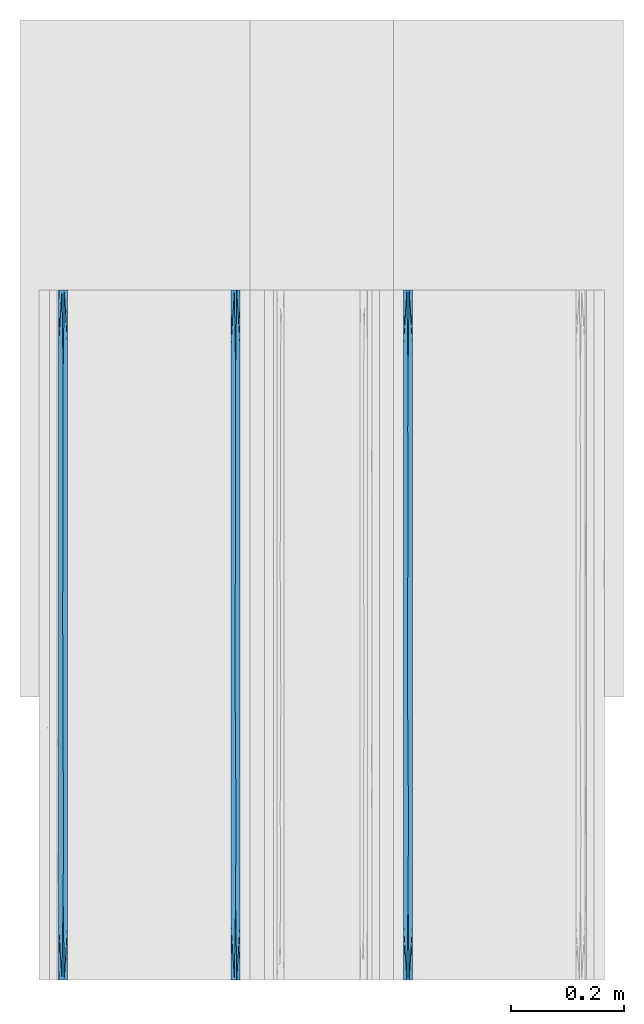
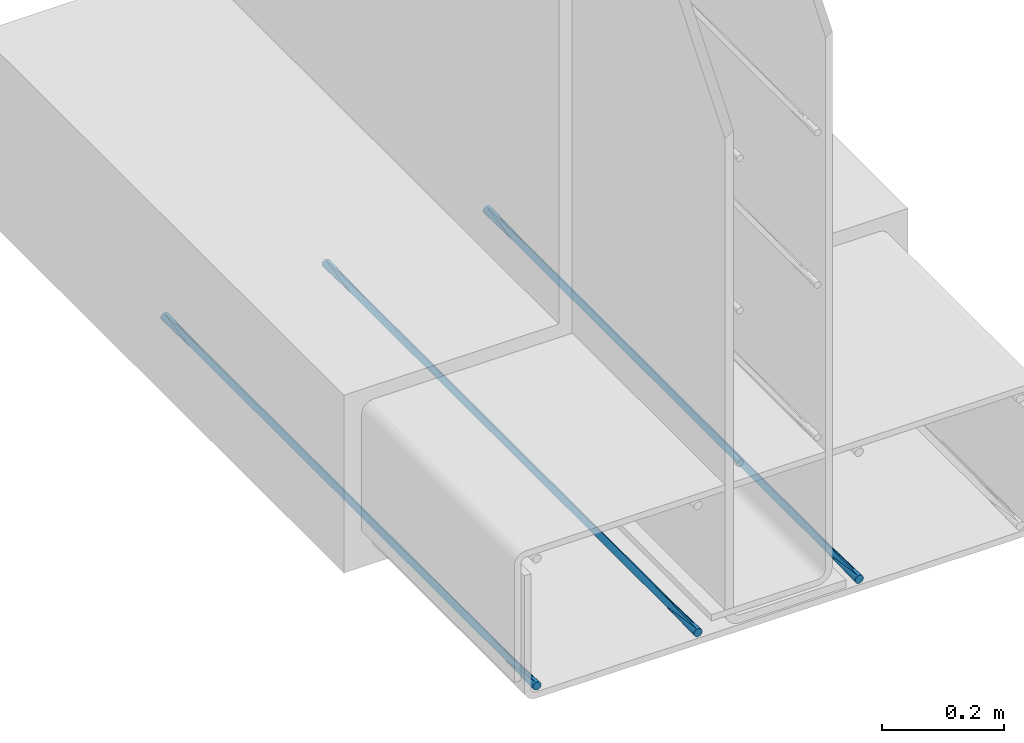
# One storey, part 5 of 10: 3 walls.
"""IFC2X3 building model written with IfcOpenShell, lengths in feet."""

import ifcopenshell
import ifcopenshell.guid

model = None  # the IFC model being written
_history = None  # IfcOwnerHistory: only IFC2X3 demands one
_inside = {}  # id of a spatial element -> (the spatial element, [elements in it])
_under = {}  # id of a project, library or spatial element -> (it, [spatial elements below it])
_declared = {}  # id of a project -> (the project, [libraries it declares])
_typed = {}  # id of a type object -> (the type object, [elements of that type])
_made_of = {}  # id of a material, layer set ... -> (it, [elements and type objects made of it])


def new_model(schema):
    """Start an empty IFC model of exactly this schema.

    Asked for "IFC4X3", IfcOpenShell would pick the latest addendum, in which some entities
    have other attributes; the version numbers below select the first issue.
    IFC2X3 requires an IfcOwnerHistory on every rooted entity: one is made here for all.
    """
    global model, _history
    if schema == "IFC4X3":
        model = ifcopenshell.file(schema_version=(4, 3, 0, 0))
    else:
        model = ifcopenshell.file(schema=schema)
    _inside.clear()
    _under.clear()
    _declared.clear()
    _typed.clear()
    _made_of.clear()
    _history = None
    if model.schema == "IFC2X3":
        org = make("IfcOrganization", Name="unknown")
        user = make(
            "IfcPersonAndOrganization",
            ThePerson=make("IfcPerson", FamilyName="unknown"),
            TheOrganization=org,
        )
        app = make(
            "IfcApplication",
            ApplicationDeveloper=org,
            Version="unknown",
            ApplicationFullName="unknown",
            ApplicationIdentifier="unknown",
        )
        _history = make(
            "IfcOwnerHistory",
            OwningUser=user,
            OwningApplication=app,
            ChangeAction="ADDED",
            CreationDate=0,
        )
    return model


def make(cls, **values):
    """One entity of the class cls with the attributes given. An attribute that is None is left unset."""
    return model.create_entity(
        cls, **{name: value for name, value in values.items() if value is not None}
    )


def entity(cls, *values):
    """Any entity or typed value of the class cls, its attributes in the order of the schema. None: left unset."""
    e = model.create_entity(cls)
    for i, value in enumerate(values):
        if value is not None:
            e[i] = value
    return e


def rooted(cls, **values):
    """An entity with a GlobalId (a new one), such as an element, a storey or a relation."""
    return make(cls, GlobalId=ifcopenshell.guid.new(), OwnerHistory=_history, **values)


def si_unit(unit_type, name, prefix=None):
    """IfcSIUnit, for example si_unit("LENGTHUNIT", "METRE", prefix="MILLI")."""
    return make("IfcSIUnit", UnitType=unit_type, Prefix=prefix, Name=name)


def converted_unit(unit_type, name, factor, base, dimensions=None, offset=None):
    """IfcConversionBasedUnit, such as the inch: factor (a typed value) times the base unit."""
    return make(
        "IfcConversionBasedUnit"
        if offset is None
        else "IfcConversionBasedUnitWithOffset",
        ConversionOffset=offset,
        Dimensions=None
        if dimensions is None
        else entity("IfcDimensionalExponents", *dimensions),
        UnitType=unit_type,
        Name=name,
        ConversionFactor=make(
            "IfcMeasureWithUnit", ValueComponent=factor, UnitComponent=base
        ),
    )


def derived_unit(unit_type, elements):
    """IfcDerivedUnit: a product of units, each with its exponent."""
    return make(
        "IfcDerivedUnit",
        Elements=[
            make("IfcDerivedUnitElement", Unit=unit, Exponent=power)
            for unit, power in elements
        ],
        UnitType=unit_type,
    )


def assignment(units):
    """IfcUnitAssignment: the units of a project."""
    return None if units is None else make("IfcUnitAssignment", Units=units)


def point(xyz):
    """IfcCartesianPoint."""
    return None if xyz is None else make("IfcCartesianPoint", Coordinates=xyz)


def direction(xyz):
    """IfcDirection."""
    return None if xyz is None else make("IfcDirection", DirectionRatios=xyz)


def frame(location, z_axis=None, x_axis=None):
    """IfcAxis2Placement3D, a coordinate frame: its origin and axes. An axis left out is left unset."""
    return make(
        "IfcAxis2Placement3D",
        Location=point(location),
        Axis=direction(z_axis),
        RefDirection=direction(x_axis),
    )


def origin():
    """The frame at (0, 0, 0) with its axes left unset."""
    return frame((0.0, 0.0, 0.0))


def place(relative_to, where):
    """IfcLocalPlacement: puts the frame where relative to a parent placement (None: the world)."""
    return make(
        "IfcLocalPlacement", PlacementRelTo=relative_to, RelativePlacement=where
    )


def context(
    kind, dimensions, precision=None, world=None, true_north=None, identifier=None
):
    """IfcGeometricRepresentationContext, for example the 3D "Model" context."""
    return make(
        "IfcGeometricRepresentationContext",
        ContextIdentifier=identifier,
        ContextType=kind,
        CoordinateSpaceDimension=dimensions,
        Precision=precision,
        WorldCoordinateSystem=world,
        TrueNorth=true_north,
    )


def subcontext(parent, identifier, kind, view, scale=None):
    """IfcGeometricRepresentationSubContext, for example "Body" below "Model"."""
    return make(
        "IfcGeometricRepresentationSubContext",
        ContextIdentifier=identifier,
        ContextType=kind,
        ParentContext=parent,
        TargetScale=scale,
        TargetView=view,
    )


def project(units=None, contexts=None):
    """IfcProject with its units and contexts."""
    return rooted(
        "IfcProject",
        Name="project",
        RepresentationContexts=contexts,
        UnitsInContext=assignment(units),
    )


def spatial(cls, under=None, at=None, **own):
    """A site, building, storey or space (cls), placed at a placement, below another one or the project."""
    s = rooted(cls, ObjectPlacement=at, **own)
    if under is not None:
        _under.setdefault(under.id(), (under, []))[1].append(s)
    return s


def faces_of(points, faces, orient=None, outer=None):
    """IfcFace entities. A face is a list of loops; a loop is a list of indices into points, from 0.

    orient and outer hold one flag for each loop. By default every Orientation is true, the
    first loop of a face is its IfcFaceOuterBound and the others are IfcFaceBound.
    """
    made = []
    for i, loops in enumerate(faces):
        bounds = []
        for j, loop in enumerate(loops):
            is_outer = j == 0 if outer is None else outer[i][j]
            bounds.append(
                make(
                    "IfcFaceOuterBound" if is_outer else "IfcFaceBound",
                    Bound=make("IfcPolyLoop", Polygon=[points[k] for k in loop]),
                    Orientation=True if orient is None else orient[i][j],
                )
            )
        made.append(make("IfcFace", Bounds=bounds))
    return made


def faceted_brep(points, faces, orient=None, outer=None, voids=None):
    """IfcFacetedBrep: a solid bounded by flat faces; with voids (closed shells), ...WithVoids."""
    shared = [point(p) for p in points]
    hull = make("IfcClosedShell", CfsFaces=faces_of(shared, faces, orient, outer))
    if voids is None:
        return make("IfcFacetedBrep", Outer=hull)
    return make(
        "IfcFacetedBrepWithVoids",
        Outer=hull,
        Voids=[
            make(cls, CfsFaces=faces_of(shared, fs, o, b)) for cls, fs, o, b in voids
        ],
    )


def shape(context_of_items, identifier, shape_type, items):
    """IfcShapeRepresentation: the items that make up one representation, for example the "Body"."""
    return make(
        "IfcShapeRepresentation",
        ContextOfItems=context_of_items,
        RepresentationIdentifier=identifier,
        RepresentationType=shape_type,
        Items=items,
    )


def material(Name=None, Category=None):
    """IfcMaterial."""
    return make("IfcMaterial", Name=Name, Category=Category)


def made_of(thing, what):
    """Note that an element or type object is made of a material, layer set ...; save() writes the relation."""
    if what is not None:
        _made_of.setdefault(what.id(), (what, []))[1].append(thing)
    return thing


def type_object(cls, material=None, **own):
    """A type object (cls), such as IfcWallType, which elements share."""
    return made_of(rooted(cls, **own), material)


def element(
    cls,
    number,
    at=None,
    inside=None,
    cuts=None,
    type_object=None,
    material=None,
    context=None,
    identifier="Body",
    shape_type=None,
    held_by="IfcProductDefinitionShape",
    body=None,
    shapes=None,
    **own,
):
    """One element of the class cls, such as IfcWall. Its Tag is "e" and its number.

    at: its placement. inside: the storey or other place that contains it. cuts: it is an
    opening in that element (IfcRelVoidsElement). A single representation is given by context,
    identifier, shape_type and body (its items); several are given by shapes. held_by: the class
    of the entity that holds the representations. save() writes the other relations.
    """
    e = rooted(cls, Tag="e%d" % number, ObjectPlacement=at, **own)
    if body is not None:
        shapes = [shape(context, identifier, shape_type, body)]
    if shapes is not None:
        e.Representation = make(held_by, Representations=shapes)
    if inside is not None:
        _inside.setdefault(inside.id(), (inside, []))[1].append(e)
    if cuts is not None:
        rooted(
            "IfcRelVoidsElement", RelatingBuildingElement=cuts, RelatedOpeningElement=e
        )
    if type_object is not None:
        _typed.setdefault(type_object.id(), (type_object, []))[1].append(e)
    return made_of(e, material)


def aggregate(whole, parts):
    """IfcRelAggregates: a whole, such as a stair, and the parts it consists of."""
    return rooted("IfcRelAggregates", RelatingObject=whole, RelatedObjects=parts)


def save(model, path):
    """Write the relations noted so far, then the file.

    IfcRelAggregates (storeys below a building ...), IfcRelContainedInSpatialStructure (elements
    in a storey), IfcRelDefinesByType, IfcRelAssociatesMaterial and IfcRelDeclares: one each for
    every whole, place, type object, material and project.
    """
    for whole, parts in _under.values():
        aggregate(whole, parts)
    for where, things in _inside.values():
        rooted(
            "IfcRelContainedInSpatialStructure",
            RelatedElements=things,
            RelatingStructure=where,
        )
    for kind, things in _typed.values():
        rooted("IfcRelDefinesByType", RelatedObjects=things, RelatingType=kind)
    for what, things in _made_of.values():
        rooted("IfcRelAssociatesMaterial", RelatedObjects=things, RelatingMaterial=what)
    for by, libraries in _declared.values():
        rooted("IfcRelDeclares", RelatingContext=by, RelatedDefinitions=libraries)
    model.write(path)


model = new_model("IFC2X3")

# Units and contexts
model_context = context("Model", 3, precision=0.0001, world=origin(), true_north=direction((6.12303176911189e-17, 1.0)))
body_context = subcontext(model_context, "Body", "Model", "MODEL_VIEW")
ifc_project = project(units=[converted_unit("LENGTHUNIT", "FOOT", entity("IfcRatioMeasure", 0.3048), si_unit("LENGTHUNIT", "METRE"), dimensions=[1, 0, 0, 0, 0, 0, 0]), converted_unit("AREAUNIT", "SQUARE FOOT", entity("IfcRatioMeasure", 0.09290304), si_unit("AREAUNIT", "SQUARE_METRE"), dimensions=[2, 0, 0, 0, 0, 0, 0]), converted_unit("VOLUMEUNIT", "CUBIC FOOT", entity("IfcRatioMeasure", 0.028316846592), si_unit("VOLUMEUNIT", "CUBIC_METRE"), dimensions=[3, 0, 0, 0, 0, 0, 0]), converted_unit("PLANEANGLEUNIT", "DEGREE", entity("IfcRatioMeasure", 0.0174532925199433), si_unit("PLANEANGLEUNIT", "RADIAN"), dimensions=[0, 0, 0, 0, 0, 0, 0]), si_unit("MASSUNIT", "GRAM", prefix="KILO"), derived_unit("MASSDENSITYUNIT", [(si_unit("MASSUNIT", "GRAM", prefix="KILO"), 1), (si_unit("LENGTHUNIT", "METRE"), -3)]), si_unit("TIMEUNIT", "SECOND"), si_unit("FREQUENCYUNIT", "HERTZ"), si_unit("THERMODYNAMICTEMPERATUREUNIT", "DEGREE_CELSIUS"), derived_unit("THERMALTRANSMITTANCEUNIT", [(si_unit("MASSUNIT", "GRAM", prefix="KILO"), 1), (si_unit("THERMODYNAMICTEMPERATUREUNIT", "KELVIN"), -1), (si_unit("TIMEUNIT", "SECOND"), -3)]), derived_unit("VOLUMETRICFLOWRATEUNIT", [(si_unit("LENGTHUNIT", "METRE"), 3), (si_unit("TIMEUNIT", "SECOND"), -1)]), si_unit("ELECTRICCURRENTUNIT", "AMPERE"), si_unit("ELECTRICVOLTAGEUNIT", "VOLT"), si_unit("POWERUNIT", "WATT"), si_unit("FORCEUNIT", "NEWTON", prefix="KILO"), si_unit("ILLUMINANCEUNIT", "LUX"), si_unit("LUMINOUSFLUXUNIT", "LUMEN"), si_unit("LUMINOUSINTENSITYUNIT", "CANDELA"), derived_unit("USERDEFINED", [(si_unit("MASSUNIT", "GRAM", prefix="KILO"), -1), (si_unit("LENGTHUNIT", "METRE"), -2), (si_unit("TIMEUNIT", "SECOND"), 3), (si_unit("LUMINOUSFLUXUNIT", "LUMEN"), 1)]), derived_unit("LINEARVELOCITYUNIT", [(si_unit("LENGTHUNIT", "METRE"), 1), (si_unit("TIMEUNIT", "SECOND"), -1)]), si_unit("PRESSUREUNIT", "PASCAL"), derived_unit("USERDEFINED", [(si_unit("LENGTHUNIT", "METRE"), -2), (si_unit("MASSUNIT", "GRAM", prefix="KILO"), 1), (si_unit("TIMEUNIT", "SECOND"), -2)])], contexts=[model_context])

# Site, building, storey
site_placement = place(None, origin())
site = spatial("IfcSite", under=ifc_project, at=site_placement, CompositionType="ELEMENT")
building_placement = place(site_placement, origin())
building = spatial("IfcBuilding", under=site, at=building_placement, CompositionType="ELEMENT")
storey_placement = place(building_placement, frame((0.0, 0.0, 11.2604166666667)))
storey = spatial("IfcBuildingStorey", under=building, at=storey_placement, Name="2ND FLOOR", CompositionType="ELEMENT", Elevation=11.2604166666667)

# Walls
ifc_material = material()
wall_type_1 = type_object("IfcWallType", Name="Generic Models 1", PredefinedType="NOTDEFINED", material=ifc_material)
wall_1_placement = place(storey_placement, frame((1428.15274703322, 0.249999999995834, 2.87899174408176), z_axis=(0.0, 0.0, 1.0), x_axis=(0.0, 1.0, 0.0)))
element("IfcWall", 1, at=wall_1_placement, inside=storey, type_object=wall_type_1, material=ifc_material, Name="Generic Models 268:Generic Models 1", ObjectType="Generic Models 268:Generic Models 1", context=body_context, shape_type="Brep", body=[
    faceted_brep([(4.0, -0.0130208333334849, 0.0034889217764551), (4.0, -0.00762742757342494, 0.0076274275732775), (4.0, -0.00348892177657945, 0.0130208333333464), (4.0, -0.000887348273863608, 0.0193015873671367), (4.0, 0.0, 0.0260416666666821), (4.0, -0.000887348273863608, 0.0327817459662274), (4.0, -0.00348892177657945, 0.0390625000000142), (4.0, -0.00762742757342494, 0.0444559057600777), (4.0, -0.0130208333334849, 0.0485944115568948), (4.0, -0.0193015873671811, 0.0511959850596142), (4.0, -0.0260416666667425, 0.0520833333333321), (4.0, -0.0327817459663038, 0.0511959850596071), (4.0, -0.0390625, 0.048594411556877), (4.0, -0.04445590576006, 0.0444559057600546), (4.0, -0.0485944115569055, 0.0390624999999858), (4.0, -0.0511959850596213, 0.0327817459661954), (4.0, -0.0520833333334849, 0.0260416666666501), (4.0, -0.0511959850596213, 0.0193015873671047), (4.0, -0.0485944115569055, 0.0130208333333179), (4.0, -0.04445590576006, 0.00762742757325441), (4.0, -0.0390625, 0.00348892177643734), (4.0, -0.0327817459663038, 0.000887348273717947), (4.0, -0.0260416666667425, 0.0), (4.0, -0.0193015873671811, 0.000887348273725053), (0.0, -0.0260416666667425, 0.0520833333333393), (0.0, -0.0193015873671811, 0.0511959850596213), (0.0, -0.0130208333334849, 0.0485944115569019), (0.0, -0.00762742757342494, 0.0444559057600848), (0.0, -0.00348892177657945, 0.0390625000000213), (0.0, -0.000887348273863608, 0.0327817459662345), (0.0, 0.0, 0.0260416666666892), (0.0, -0.000887348273863608, 0.0193015873671438), (0.0, -0.00348892177657945, 0.0130208333333535), (0.0, -0.00762742757342494, 0.00762742757328461), (0.0, -0.0130208333334849, 0.00348892177646221), (0.0, -0.0193015873671811, 0.000887348273732158), (0.0, -0.0260416666667425, 0.0), (0.0, -0.0327817459663038, 0.000887348273725053), (0.0, -0.0390625, 0.00348892177644444), (0.0, -0.04445590576006, 0.00762742757326151), (0.0, -0.0485944115569055, 0.013020833333325), (0.0, -0.0511959850596213, 0.0193015873671119), (0.0, -0.0520833333334849, 0.0260416666666572), (0.0, -0.0511959850596213, 0.0327817459662025), (0.0, -0.0485944115569055, 0.0390624999999929), (0.0, -0.04445590576006, 0.0444559057600618), (0.0, -0.0390625, 0.0485944115568842), (0.0, -0.0327817459663038, 0.0511959850596142), (3.67725138549306, 0.0, 0.0260416666666821), (0.32274862547415, -0.0520833333334849, 0.0260416666666554), (3.67725140296933, -0.0520833333334849, 0.0260416666666501), (3.51587705267192, -0.0260416670323593, 0.0), (2.87037982919681, -0.0260416666374113, 0.0), (2.52958652603254, -0.026227183774381, 6.60807051744428e-07), (2.70900554197223, 0.0, 0.0260416666666838), (2.70900552654688, -0.0520833333334849, 0.0260416666666519), (1.90213399266994, -0.0280271573828941, 7.58000453888741e-05), (1.5, 0.0, 0.0260416666666874), (1.74075971428411, 0.0, 0.0260416666666856), (2.0, 0.0, 0.0260416666666856), (1.58481828942483, -0.0281065462752395, 8.19926513742075e-05), (2.35450277098611, 0.0, 0.0260416666666838), (2.38625689346174, 0.0, 0.0260416666666838), (0.322748614506943, 0.0, 0.0260416666666892), (0.484122917594275, -0.0260416666644687, 0.0), (0.645497229013885, 0.0, 0.0260416666666874), (3.03175415647917, 0.0, 0.0260416666666838), (3.35450277098611, 0.0, 0.0260416666666838), (0.802626606099821, -0.0241210785507064, 7.09188132521632e-05), (1.0, 0.0, 0.0260416666666874), (1.12499999124347, -0.0246126796300814, 3.92360336185504e-05), (3.35450277749518, -0.0520833333334849, 0.0260416666666519), (2.2160433903769, -0.0283845183157609, 0.000105602028249052), (2.06350830404206, -0.0520833333334849, 0.0260416666666536), (2.00000002040847, -0.0520833333334849, 0.0260416666666536), (1.74075970701139, -0.0520833333334849, 0.0260416666666554), (3.19312844079874, -0.0276322430397613, 4.86201045735157e-05), (3.03175415202103, -0.0520833333334849, 0.0260416666666519), (0.70900554076862, -0.0520833333334849, 0.0260416666666554), (0.645497257127644, -0.0520833333332575, 0.0260416666666554), (1.41801108153724, -0.0520833333334849, 0.0260416666666554), (1.25, 0.0, 0.0260416666666874), (1.41801107183056, 0.0, 0.0260416666666856), (2.38625690107273, -0.0520833333334849, 0.0260416666666519), (2.06350830387292, 0.0, 0.0260416666666838), (1.50000002551058, -0.0520833333334849, 0.0260416666666536), (1.25000002806164, -0.0520833333334849, 0.0260416666666554), (1.06350832537467, -0.0520833333334849, 0.0260416666666554), (1.06350827744056, 0.0, 0.0260416666666874), (1.0000000306127, -0.0520833333334849, 0.0260416666666554), (2.35450279389352, -0.0520833333334849, 0.0260416666666519), (0.70900553591528, 0.0, 0.0260416666666892), (1.90213399388276, -0.0240561759483171, 0.0520075332877745), (3.51587705385881, -0.0260416658200029, 0.0520833333333339), (2.87037983051048, -0.0260416667615573, 0.0520833333333339), (2.52958652644354, -0.0258561495911636, 0.0520826725265131), (0.484122917756005, -0.0260416666742458, 0.0520833333333393), (3.19312844116365, -0.0244510900004116, 0.0520347132108157), (1.58481829017475, -0.023976787102356, 0.0520013406854787), (1.12499999099503, -0.0274706537484235, 0.052044097297248), (0.802626606321884, -0.0279622548152929, 0.0520124145176908), (2.2160433912069, -0.023698814974523, 0.051977731301184)], [[[0, 1, 2, 3, 4, 5, 6, 7, 8, 9, 10, 11, 12, 13, 14, 15, 16, 17, 18, 19, 20, 21, 22, 23]], [[24, 25, 26, 27, 28, 29, 30, 31, 32, 33, 34, 35, 36, 37, 38, 39, 40, 41, 42, 43, 44, 45, 46, 47]], [[2, 48, 3]], [[49, 42, 41]], [[17, 16, 50]], [[20, 50, 21]], [[50, 51, 21]], [[40, 49, 41]], [[52, 53, 54]], [[52, 55, 53]], [[50, 19, 18]], [[56, 57, 58, 59]], [[38, 37, 49]], [[60, 57, 56]], [[0, 48, 1]], [[53, 61, 62, 54]], [[63, 32, 31]], [[64, 63, 65]], [[52, 54, 66]], [[48, 51, 67]], [[68, 69, 70]], [[23, 22, 51]], [[35, 64, 36]], [[2, 1, 48]], [[18, 17, 50]], [[19, 50, 20]], [[50, 71, 51]], [[56, 72, 73]], [[56, 73, 74, 75]], [[67, 51, 76]], [[55, 52, 77]], [[64, 78, 79, 49]], [[39, 38, 49]], [[0, 23, 48]], [[48, 23, 51]], [[60, 80, 70]], [[64, 65, 68]], [[37, 36, 64]], [[51, 22, 21]], [[60, 81, 82, 57]], [[40, 39, 49]], [[32, 63, 33]], [[77, 52, 76]], [[66, 67, 76]], [[34, 33, 63]], [[71, 77, 76]], [[35, 63, 64]], [[34, 63, 35]], [[48, 4, 3]], [[31, 30, 63]], [[53, 72, 61]], [[53, 83, 72]], [[64, 49, 37]], [[56, 75, 60]], [[72, 59, 84, 61]], [[60, 75, 85, 80]], [[70, 81, 60]], [[64, 68, 78]], [[70, 80, 86, 87]], [[70, 69, 88, 81]], [[68, 87, 89, 78]], [[72, 56, 59]], [[83, 53, 55]], [[72, 83, 90, 73]], [[76, 52, 66]], [[71, 76, 51]], [[68, 65, 91, 69]], [[87, 68, 70]], [[92, 84, 59, 58]], [[14, 50, 15]], [[8, 48, 9]], [[48, 93, 9]], [[28, 63, 29]], [[94, 95, 55]], [[44, 43, 49]], [[94, 54, 95]], [[47, 96, 24]], [[11, 10, 93]], [[5, 4, 48]], [[63, 30, 29]], [[66, 94, 97]], [[98, 85, 92]], [[12, 50, 13]], [[98, 86, 80, 85]], [[89, 99, 100]], [[49, 79, 96]], [[96, 91, 65, 63]], [[7, 48, 8]], [[48, 6, 5]], [[14, 13, 50]], [[48, 7, 6]], [[50, 93, 71]], [[48, 67, 93]], [[92, 101, 84]], [[12, 11, 50]], [[66, 54, 94]], [[95, 90, 83, 55]], [[27, 26, 63]], [[50, 11, 93]], [[96, 79, 100]], [[98, 82, 99]], [[92, 85, 75, 74]], [[24, 96, 25]], [[93, 10, 9]], [[97, 77, 71]], [[28, 27, 63]], [[44, 49, 45]], [[50, 16, 15]], [[43, 42, 49]], [[93, 97, 71]], [[46, 45, 49]], [[67, 66, 97]], [[47, 49, 96]], [[46, 49, 47]], [[26, 25, 63]], [[95, 101, 90]], [[95, 62, 101]], [[96, 63, 25]], [[92, 58, 98]], [[101, 74, 73, 90]], [[98, 58, 57, 82]], [[99, 86, 98]], [[96, 100, 91]], [[99, 82, 81, 88]], [[99, 89, 87, 86]], [[100, 88, 69, 91]], [[101, 92, 74]], [[94, 55, 77]], [[62, 95, 54]], [[101, 62, 61, 84]], [[97, 94, 77]], [[67, 97, 93]], [[100, 79, 78, 89]], [[88, 100, 99]]]),
])
wall_type_2 = type_object("IfcWallType", Name="Generic Models 1", PredefinedType="NOTDEFINED", material=ifc_material)
wall_2_placement = place(storey_placement, frame((1429.15274703322, 0.24999999999583, 2.87899174408175), z_axis=(0.0, 0.0, 1.0), x_axis=(0.0, 1.0, 0.0)))
element("IfcWall", 2, at=wall_2_placement, inside=storey, type_object=wall_type_2, material=ifc_material, Name="Generic Models 269:Generic Models 1", ObjectType="Generic Models 269:Generic Models 1", context=body_context, shape_type="Brep", body=[
    faceted_brep([(4.0, -0.0130208333334849, 0.0034889217764551), (4.0, -0.00762742757342494, 0.0076274275732775), (4.0, -0.00348892177657945, 0.0130208333333464), (4.0, -0.000887348273863608, 0.0193015873671367), (4.0, 0.0, 0.0260416666666821), (4.0, -0.000887348273863608, 0.0327817459662274), (4.0, -0.00348892177657945, 0.0390625000000142), (4.0, -0.00762742757342494, 0.0444559057600777), (4.0, -0.0130208333334849, 0.0485944115568948), (4.0, -0.0193015873671811, 0.0511959850596142), (4.0, -0.0260416666667425, 0.0520833333333321), (4.0, -0.0327817459663038, 0.0511959850596071), (4.0, -0.0390625, 0.048594411556877), (4.0, -0.04445590576006, 0.0444559057600546), (4.0, -0.0485944115569055, 0.0390624999999858), (4.0, -0.0511959850596213, 0.0327817459661954), (4.0, -0.0520833333334849, 0.0260416666666501), (4.0, -0.0511959850596213, 0.0193015873671047), (4.0, -0.0485944115569055, 0.0130208333333179), (4.0, -0.04445590576006, 0.00762742757325441), (4.0, -0.0390625, 0.00348892177643734), (4.0, -0.0327817459663038, 0.000887348273717947), (4.0, -0.0260416666667425, 0.0), (4.0, -0.0193015873671811, 0.000887348273725053), (0.0, -0.0260416666667425, 0.0520833333333393), (0.0, -0.0193015873671811, 0.0511959850596213), (0.0, -0.0130208333334849, 0.0485944115569019), (0.0, -0.00762742757342494, 0.0444559057600848), (0.0, -0.00348892177657945, 0.0390625000000213), (0.0, -0.000887348273863608, 0.0327817459662345), (0.0, 0.0, 0.0260416666666892), (0.0, -0.000887348273863608, 0.0193015873671438), (0.0, -0.00348892177657945, 0.0130208333333535), (0.0, -0.00762742757342494, 0.00762742757328461), (0.0, -0.0130208333334849, 0.00348892177646221), (0.0, -0.0193015873671811, 0.000887348273732158), (0.0, -0.0260416666667425, 0.0), (0.0, -0.0327817459663038, 0.000887348273725053), (0.0, -0.0390625, 0.00348892177644444), (0.0, -0.04445590576006, 0.00762742757326151), (0.0, -0.0485944115569055, 0.013020833333325), (0.0, -0.0511959850596213, 0.0193015873671119), (0.0, -0.0520833333334849, 0.0260416666666572), (0.0, -0.0511959850596213, 0.0327817459662025), (0.0, -0.0485944115569055, 0.0390624999999929), (0.0, -0.04445590576006, 0.0444559057600618), (0.0, -0.0390625, 0.0485944115568842), (0.0, -0.0327817459663038, 0.0511959850596142), (3.67725138549306, 0.0, 0.0260416666666838), (0.32274862547415, -0.0520833333334849, 0.0260416666666572), (3.67725140296933, -0.0520833333332575, 0.0260416666666501), (3.51587705267192, -0.0260416670323593, 0.0), (2.87037982919681, -0.0260416666374113, 0.0), (2.52958652603254, -0.026227183774381, 6.60807051744428e-07), (2.70900554197223, 0.0, 0.0260416666666838), (2.70900552654688, -0.0520833333334849, 0.0260416666666519), (1.90213399266994, -0.0280271573828941, 7.58000453888741e-05), (1.5, 0.0, 0.0260416666666874), (1.74075971428411, 0.0, 0.0260416666666856), (2.0, 0.0, 0.0260416666666856), (1.58481828942483, -0.0281065462752395, 8.19926513742075e-05), (2.35450277098611, 0.0, 0.0260416666666856), (2.38625689346174, 0.0, 0.0260416666666856), (0.322748614506943, 0.0, 0.0260416666666874), (0.484122917594275, -0.0260416666644687, 0.0), (0.645497229013885, 0.0, 0.0260416666666874), (3.03175415647917, 0.0, 0.0260416666666838), (3.35450277098611, 0.0, 0.0260416666666838), (0.802626606099821, -0.0241210785507064, 7.09188132521632e-05), (1.0, 0.0, 0.0260416666666874), (1.12499999124347, -0.0246126796300814, 3.92360336185504e-05), (3.35450277749518, -0.0520833333334849, 0.0260416666666501), (2.2160433903769, -0.0283845183157609, 0.000105602028249052), (2.06350830404206, -0.0520833333334849, 0.0260416666666536), (2.00000002040847, -0.0520833333334849, 0.0260416666666536), (1.74075970701139, -0.0520833333334849, 0.0260416666666554), (3.19312844079874, -0.0276322430397613, 4.86201045735157e-05), (3.03175415202103, -0.0520833333334849, 0.0260416666666519), (0.70900554076862, -0.0520833333334849, 0.0260416666666554), (0.645497257127644, -0.0520833333334849, 0.0260416666666554), (1.41801108153724, -0.0520833333334849, 0.0260416666666554), (1.25, 0.0, 0.0260416666666874), (1.41801107183056, 0.0, 0.0260416666666874), (2.38625690107273, -0.0520833333334849, 0.0260416666666536), (2.06350830387292, 0.0, 0.0260416666666856), (1.50000002551058, -0.0520833333334849, 0.0260416666666554), (1.25000002806164, -0.0520833333334849, 0.0260416666666554), (1.06350832537467, -0.0520833333334849, 0.0260416666666554), (1.06350827744056, 0.0, 0.0260416666666874), (1.0000000306127, -0.0520833333334849, 0.0260416666666554), (2.35450279389352, -0.0520833333334849, 0.0260416666666519), (0.70900553591528, 0.0, 0.0260416666666874), (1.90213399388276, -0.0240561759483171, 0.0520075332877745), (3.51587705385881, -0.0260416658200029, 0.0520833333333339), (2.87037983051048, -0.0260416667615573, 0.0520833333333339), (2.52958652644354, -0.0258561495911636, 0.0520826725265131), (0.484122917756005, -0.0260416666742458, 0.0520833333333393), (3.19312844116365, -0.0244510900004116, 0.0520347132108157), (1.58481829017475, -0.023976787102356, 0.0520013406854787), (1.12499999099503, -0.0274706537484235, 0.052044097297248), (0.802626606321884, -0.0279622548152929, 0.0520124145176908), (2.2160433912069, -0.023698814974523, 0.051977731301184)], [[[0, 1, 2, 3, 4, 5, 6, 7, 8, 9, 10, 11, 12, 13, 14, 15, 16, 17, 18, 19, 20, 21, 22, 23]], [[24, 25, 26, 27, 28, 29, 30, 31, 32, 33, 34, 35, 36, 37, 38, 39, 40, 41, 42, 43, 44, 45, 46, 47]], [[2, 48, 3]], [[49, 42, 41]], [[17, 16, 50]], [[20, 50, 21]], [[50, 51, 21]], [[40, 49, 41]], [[52, 53, 54]], [[52, 55, 53]], [[50, 19, 18]], [[56, 57, 58, 59]], [[38, 37, 49]], [[60, 57, 56]], [[0, 48, 1]], [[53, 61, 62, 54]], [[63, 32, 31]], [[64, 63, 65]], [[52, 54, 66]], [[48, 51, 67]], [[68, 69, 70]], [[23, 22, 51]], [[35, 64, 36]], [[2, 1, 48]], [[18, 17, 50]], [[19, 50, 20]], [[50, 71, 51]], [[56, 72, 73]], [[56, 73, 74, 75]], [[67, 51, 76]], [[55, 52, 77]], [[64, 78, 79, 49]], [[39, 38, 49]], [[0, 23, 48]], [[48, 23, 51]], [[60, 80, 70]], [[64, 65, 68]], [[37, 36, 64]], [[51, 22, 21]], [[60, 81, 82, 57]], [[40, 39, 49]], [[32, 63, 33]], [[77, 52, 76]], [[66, 67, 76]], [[34, 33, 63]], [[71, 77, 76]], [[35, 63, 64]], [[34, 63, 35]], [[48, 4, 3]], [[31, 30, 63]], [[53, 72, 61]], [[53, 83, 72]], [[64, 49, 37]], [[56, 75, 60]], [[72, 59, 84, 61]], [[60, 75, 85, 80]], [[70, 81, 60]], [[64, 68, 78]], [[70, 80, 86, 87]], [[70, 69, 88, 81]], [[68, 87, 89, 78]], [[72, 56, 59]], [[83, 53, 55]], [[72, 83, 90, 73]], [[76, 52, 66]], [[71, 76, 51]], [[68, 65, 91, 69]], [[87, 68, 70]], [[92, 84, 59, 58]], [[14, 50, 15]], [[8, 48, 9]], [[48, 93, 9]], [[28, 63, 29]], [[94, 95, 55]], [[44, 43, 49]], [[94, 54, 95]], [[47, 96, 24]], [[11, 10, 93]], [[5, 4, 48]], [[63, 30, 29]], [[66, 94, 97]], [[98, 85, 92]], [[12, 50, 13]], [[98, 86, 80, 85]], [[89, 99, 100]], [[49, 79, 96]], [[96, 91, 65, 63]], [[7, 48, 8]], [[48, 6, 5]], [[14, 13, 50]], [[48, 7, 6]], [[50, 93, 71]], [[48, 67, 93]], [[92, 101, 84]], [[12, 11, 50]], [[66, 54, 94]], [[95, 90, 83, 55]], [[27, 26, 63]], [[50, 11, 93]], [[96, 79, 100]], [[98, 82, 99]], [[92, 85, 75, 74]], [[24, 96, 25]], [[93, 10, 9]], [[97, 77, 71]], [[28, 27, 63]], [[44, 49, 45]], [[50, 16, 15]], [[43, 42, 49]], [[93, 97, 71]], [[46, 45, 49]], [[67, 66, 97]], [[47, 49, 96]], [[46, 49, 47]], [[26, 25, 63]], [[95, 101, 90]], [[95, 62, 101]], [[96, 63, 25]], [[92, 58, 98]], [[101, 74, 73, 90]], [[98, 58, 57, 82]], [[99, 86, 98]], [[96, 100, 91]], [[99, 82, 81, 88]], [[99, 89, 87, 86]], [[100, 88, 69, 91]], [[101, 92, 74]], [[94, 55, 77]], [[62, 95, 54]], [[101, 62, 61, 84]], [[97, 94, 77]], [[67, 97, 93]], [[100, 79, 78, 89]], [[88, 100, 99]]]),
])
wall_type_3 = type_object("IfcWallType", Name="Generic Models 1", PredefinedType="NOTDEFINED", material=ifc_material)
wall_3_placement = place(storey_placement, frame((1430.15274703322, 0.249999999995827, 2.87899174408175), z_axis=(0.0, 0.0, 1.0), x_axis=(0.0, 1.0, 0.0)))
element("IfcWall", 3, at=wall_3_placement, inside=storey, type_object=wall_type_3, material=ifc_material, Name="Generic Models 271:Generic Models 1", ObjectType="Generic Models 271:Generic Models 1", context=body_context, shape_type="Brep", body=[
    faceted_brep([(4.0, -0.0130208333334849, 0.0034889217764551), (4.0, -0.00762742757342494, 0.0076274275732775), (4.0, -0.00348892177657945, 0.0130208333333464), (4.0, -0.000887348273863608, 0.0193015873671367), (4.0, 0.0, 0.0260416666666821), (4.0, -0.000887348273863608, 0.0327817459662274), (4.0, -0.00348892177657945, 0.0390625000000142), (4.0, -0.00762742757342494, 0.0444559057600777), (4.0, -0.0130208333334849, 0.0485944115568948), (4.0, -0.0193015873671811, 0.0511959850596142), (4.0, -0.0260416666667425, 0.0520833333333321), (4.0, -0.0327817459663038, 0.0511959850596071), (4.0, -0.0390625, 0.048594411556877), (4.0, -0.04445590576006, 0.0444559057600546), (4.0, -0.0485944115569055, 0.0390624999999858), (4.0, -0.0511959850596213, 0.0327817459661954), (4.0, -0.0520833333334849, 0.0260416666666501), (4.0, -0.0511959850596213, 0.0193015873671047), (4.0, -0.0485944115569055, 0.0130208333333179), (4.0, -0.04445590576006, 0.00762742757325441), (4.0, -0.0390625, 0.00348892177643734), (4.0, -0.0327817459663038, 0.000887348273717947), (4.0, -0.0260416666667425, 0.0), (4.0, -0.0193015873671811, 0.000887348273725053), (0.0, -0.0260416666667425, 0.0520833333333393), (0.0, -0.0193015873671811, 0.0511959850596213), (0.0, -0.0130208333334849, 0.0485944115569019), (0.0, -0.00762742757342494, 0.0444559057600848), (0.0, -0.00348892177657945, 0.0390625000000213), (0.0, -0.000887348273863608, 0.0327817459662345), (0.0, 0.0, 0.0260416666666892), (0.0, -0.000887348273863608, 0.0193015873671438), (0.0, -0.00348892177657945, 0.0130208333333535), (0.0, -0.00762742757342494, 0.00762742757328461), (0.0, -0.0130208333334849, 0.00348892177646221), (0.0, -0.0193015873671811, 0.000887348273732158), (0.0, -0.0260416666667425, 0.0), (0.0, -0.0327817459663038, 0.000887348273725053), (0.0, -0.0390625, 0.00348892177644444), (0.0, -0.04445590576006, 0.00762742757326151), (0.0, -0.0485944115569055, 0.013020833333325), (0.0, -0.0511959850596213, 0.0193015873671119), (0.0, -0.0520833333334849, 0.0260416666666572), (0.0, -0.0511959850596213, 0.0327817459662025), (0.0, -0.0485944115569055, 0.0390624999999929), (0.0, -0.04445590576006, 0.0444559057600618), (0.0, -0.0390625, 0.0485944115568842), (0.0, -0.0327817459663038, 0.0511959850596142), (3.67725138549306, 0.0, 0.0260416666666838), (0.32274862547415, -0.0520833333334849, 0.0260416666666572), (3.67725140296933, -0.0520833333334849, 0.0260416666666501), (3.51587705267192, -0.0260416670323593, 0.0), (2.87037982919681, -0.0260416666374113, 0.0), (2.52958652603254, -0.026227183774381, 6.60807051744428e-07), (2.70900554197223, 0.0, 0.0260416666666838), (2.70900552654688, -0.0520833333334849, 0.0260416666666519), (1.90213399266994, -0.0280271573828941, 7.58000453888741e-05), (1.5, 0.0, 0.0260416666666874), (1.74075971428411, 0.0, 0.0260416666666856), (2.0, 0.0, 0.0260416666666856), (1.58481828942483, -0.0281065462752395, 8.19926513742075e-05), (2.35450277098611, 0.0, 0.0260416666666856), (2.38625689346174, 0.0, 0.0260416666666856), (0.322748614506943, 0.0, 0.0260416666666874), (0.484122917594275, -0.0260416666644687, 0.0), (0.645497229013885, 0.0, 0.0260416666666874), (3.03175415647917, 0.0, 0.0260416666666838), (3.35450277098611, 0.0, 0.0260416666666838), (0.802626606099821, -0.0241210785507064, 7.09188132521632e-05), (1.0, 0.0, 0.0260416666666874), (1.12499999124347, -0.0246126796300814, 3.92360336185504e-05), (3.35450277749518, -0.0520833333334849, 0.0260416666666501), (2.2160433903769, -0.0283845183157609, 0.000105602028249052), (2.06350830404206, -0.0520833333334849, 0.0260416666666536), (2.00000002040847, -0.0520833333334849, 0.0260416666666536), (1.74075970701139, -0.0520833333334849, 0.0260416666666554), (3.19312844079874, -0.0276322430397613, 4.86201045735157e-05), (3.03175415202103, -0.0520833333334849, 0.0260416666666519), (0.70900554076862, -0.0520833333334849, 0.0260416666666554), (0.645497257127644, -0.0520833333334849, 0.0260416666666554), (1.41801108153724, -0.0520833333334849, 0.0260416666666554), (1.25, 0.0, 0.0260416666666874), (1.41801107183056, 0.0, 0.0260416666666874), (2.38625690107273, -0.0520833333334849, 0.0260416666666536), (2.06350830387292, 0.0, 0.0260416666666856), (1.50000002551058, -0.0520833333334849, 0.0260416666666554), (1.25000002806164, -0.0520833333334849, 0.0260416666666554), (1.06350832537467, -0.0520833333334849, 0.0260416666666554), (1.06350827744056, 0.0, 0.0260416666666874), (1.0000000306127, -0.0520833333334849, 0.0260416666666554), (2.35450279389352, -0.0520833333334849, 0.0260416666666519), (0.70900553591528, 0.0, 0.0260416666666874), (1.90213399388276, -0.0240561759483171, 0.0520075332877745), (3.51587705385881, -0.0260416658200029, 0.0520833333333339), (2.87037983051048, -0.0260416667615573, 0.0520833333333339), (2.52958652644354, -0.0258561495911636, 0.0520826725265131), (0.484122917756005, -0.0260416666742458, 0.0520833333333393), (3.19312844116365, -0.0244510900004116, 0.0520347132108157), (1.58481829017475, -0.023976787102356, 0.0520013406854787), (1.12499999099503, -0.0274706537484235, 0.052044097297248), (0.802626606321884, -0.0279622548152929, 0.0520124145176908), (2.2160433912069, -0.023698814974523, 0.051977731301184)], [[[0, 1, 2, 3, 4, 5, 6, 7, 8, 9, 10, 11, 12, 13, 14, 15, 16, 17, 18, 19, 20, 21, 22, 23]], [[24, 25, 26, 27, 28, 29, 30, 31, 32, 33, 34, 35, 36, 37, 38, 39, 40, 41, 42, 43, 44, 45, 46, 47]], [[2, 48, 3]], [[49, 42, 41]], [[17, 16, 50]], [[20, 50, 21]], [[50, 51, 21]], [[40, 49, 41]], [[52, 53, 54]], [[52, 55, 53]], [[50, 19, 18]], [[56, 57, 58, 59]], [[38, 37, 49]], [[60, 57, 56]], [[0, 48, 1]], [[53, 61, 62, 54]], [[63, 32, 31]], [[64, 63, 65]], [[52, 54, 66]], [[48, 51, 67]], [[68, 69, 70]], [[23, 22, 51]], [[35, 64, 36]], [[2, 1, 48]], [[18, 17, 50]], [[19, 50, 20]], [[50, 71, 51]], [[56, 72, 73]], [[56, 73, 74, 75]], [[67, 51, 76]], [[55, 52, 77]], [[64, 78, 79, 49]], [[39, 38, 49]], [[0, 23, 48]], [[48, 23, 51]], [[60, 80, 70]], [[64, 65, 68]], [[37, 36, 64]], [[51, 22, 21]], [[60, 81, 82, 57]], [[40, 39, 49]], [[32, 63, 33]], [[77, 52, 76]], [[66, 67, 76]], [[34, 33, 63]], [[71, 77, 76]], [[35, 63, 64]], [[34, 63, 35]], [[48, 4, 3]], [[31, 30, 63]], [[53, 72, 61]], [[53, 83, 72]], [[64, 49, 37]], [[56, 75, 60]], [[72, 59, 84, 61]], [[60, 75, 85, 80]], [[70, 81, 60]], [[64, 68, 78]], [[70, 80, 86, 87]], [[70, 69, 88, 81]], [[68, 87, 89, 78]], [[72, 56, 59]], [[83, 53, 55]], [[72, 83, 90, 73]], [[76, 52, 66]], [[71, 76, 51]], [[68, 65, 91, 69]], [[87, 68, 70]], [[92, 84, 59, 58]], [[14, 50, 15]], [[8, 48, 9]], [[48, 93, 9]], [[28, 63, 29]], [[94, 95, 55]], [[44, 43, 49]], [[94, 54, 95]], [[47, 96, 24]], [[11, 10, 93]], [[5, 4, 48]], [[63, 30, 29]], [[66, 94, 97]], [[98, 85, 92]], [[12, 50, 13]], [[98, 86, 80, 85]], [[89, 99, 100]], [[49, 79, 96]], [[96, 91, 65, 63]], [[7, 48, 8]], [[48, 6, 5]], [[14, 13, 50]], [[48, 7, 6]], [[50, 93, 71]], [[48, 67, 93]], [[92, 101, 84]], [[12, 11, 50]], [[66, 54, 94]], [[95, 90, 83, 55]], [[27, 26, 63]], [[50, 11, 93]], [[96, 79, 100]], [[98, 82, 99]], [[92, 85, 75, 74]], [[24, 96, 25]], [[93, 10, 9]], [[97, 77, 71]], [[28, 27, 63]], [[44, 49, 45]], [[50, 16, 15]], [[43, 42, 49]], [[93, 97, 71]], [[46, 45, 49]], [[67, 66, 97]], [[47, 49, 96]], [[46, 49, 47]], [[26, 25, 63]], [[95, 101, 90]], [[95, 62, 101]], [[96, 63, 25]], [[92, 58, 98]], [[101, 74, 73, 90]], [[98, 58, 57, 82]], [[99, 86, 98]], [[96, 100, 91]], [[99, 82, 81, 88]], [[99, 89, 87, 86]], [[100, 88, 69, 91]], [[101, 92, 74]], [[94, 55, 77]], [[62, 95, 54]], [[101, 62, 61, 84]], [[97, 94, 77]], [[67, 97, 93]], [[100, 79, 78, 89]], [[88, 100, 99]]]),
])

save(model, "model.ifc")
